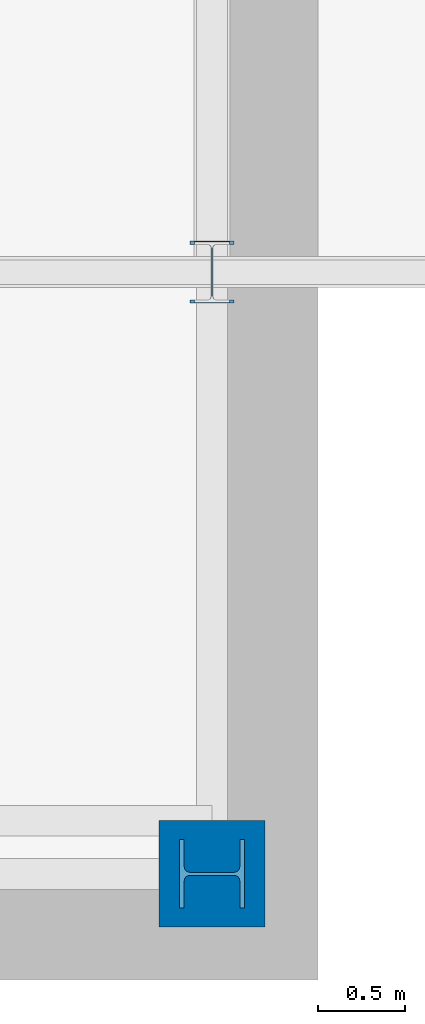
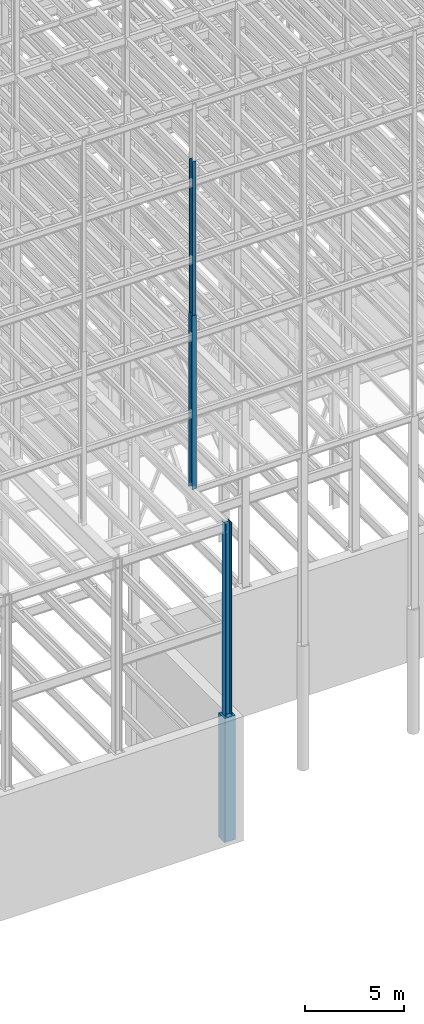
# One storey, part 24 of 150: 4 columns.
"""IFC2X3 building model written with IfcOpenShell, lengths in millimetres."""

from ifc_helpers import new_model, si_unit, frame, origin_with_axes, origin_2d_with_axis, place, context, subcontext, project, spatial, rectangle, i_section, extrude, material, type_object, element, save


model = new_model("IFC2X3")

# Units and contexts
model_context = context("Model", 3, precision=1e-05, world=origin_with_axes())
body_context = subcontext(model_context, "Body", "Model", "MODEL_VIEW")
ifc_project = project(units=[si_unit("LENGTHUNIT", "METRE", prefix="MILLI"), si_unit("AREAUNIT", "SQUARE_METRE"), si_unit("VOLUMEUNIT", "CUBIC_METRE"), si_unit("MASSUNIT", "GRAM", prefix="KILO"), si_unit("TIMEUNIT", "SECOND"), si_unit("PLANEANGLEUNIT", "RADIAN"), si_unit("SOLIDANGLEUNIT", "STERADIAN"), si_unit("THERMODYNAMICTEMPERATUREUNIT", "DEGREE_CELSIUS"), si_unit("LUMINOUSINTENSITYUNIT", "LUMEN")], contexts=[model_context])

# Site, building, storey
site_placement = place(None, origin_with_axes())
site = spatial("IfcSite", under=ifc_project, at=site_placement, CompositionType="ELEMENT")
building_placement = place(site_placement, origin_with_axes())
building = spatial("IfcBuilding", under=site, at=building_placement, Name="Undefined", CompositionType="ELEMENT")
storey_placement = place(building_placement, origin_with_axes())
storey = spatial("IfcBuildingStorey", under=building, at=storey_placement, Name="Undefined", CompositionType="ELEMENT", Elevation=0.0)

# Columns
ifc_material_1 = material(Name="STEEL/A992")
column_type_1 = type_object("IfcColumnType", Name="W14X53", PredefinedType="NOTDEFINED")
column_1_placement = place(storey_placement, frame((43789.6, 3454.40000000001, 46253.4), z_axis=(0.0, 0.0, 1.0), x_axis=(1.0, 0.0, 0.0)))
element("IfcColumn", 1, at=column_1_placement, inside=storey, type_object=column_type_1, material=ifc_material_1, Name="COLUMN", ObjectType="W14X53", context=body_context, shape_type="SweptSolid", body=[
    extrude(i_section(OverallWidth=203.2, OverallDepth=352.425, WebThickness=9.5249, FlangeThickness=16.764, FilletRadius=21.336, at=origin_2d_with_axis()), frame((0.0, 0.0, 9448.8), z_axis=(0.0, 0.0, -1.0), x_axis=(-1.0, 0.0, 0.0)), (0.0, 0.0, 1.0), 9448.8),
])
column_type_2 = type_object("IfcColumnType", Name="W14X68", PredefinedType="NOTDEFINED")
column_2_placement = place(storey_placement, frame((43789.6, 3454.40000000001, 35585.4), z_axis=(0.0, 0.0, 1.0), x_axis=(1.0, 0.0, 0.0)))
element("IfcColumn", 2, at=column_2_placement, inside=storey, type_object=column_type_2, material=ifc_material_1, Name="COLUMN", ObjectType="W14X68", context=body_context, shape_type="SweptSolid", body=[
    extrude(i_section(OverallWidth=254.0, OverallDepth=355.6, WebThickness=11.1125, FlangeThickness=18.288, FilletRadius=21.3994, at=origin_2d_with_axis()), frame((0.0, 0.0, 10667.9989332), z_axis=(0.0, 0.0, -1.0), x_axis=(-1.0, 0.0, 0.0)), (0.0, 0.0, 1.0), 10667.9989332),
])
column_type_3 = type_object("IfcColumnType", Name="W14X145", PredefinedType="NOTDEFINED")
column_3_placement = place(storey_placement, frame((43789.6, 0.0, 22707.6), z_axis=(0.0, 0.0, 1.0), x_axis=(1.0, 0.0, 0.0)))
element("IfcColumn", 3, at=column_3_placement, inside=storey, type_object=column_type_3, material=ifc_material_1, Name="COLUMN", ObjectType="W14X145", context=body_context, shape_type="SweptSolid", body=[
    extrude(i_section(OverallWidth=393.7, OverallDepth=374.65, WebThickness=17.4625, FlangeThickness=27.686, FilletRadius=32.6389, at=origin_2d_with_axis()), frame((0.0, 0.0, 12877.8), z_axis=(0.0, 0.0, -1.0), x_axis=(0.0, -1.0, 0.0)), (0.0, 0.0, 1.0), 12877.8),
])
ifc_material_2 = material(Name="CONCRETE/5000")
column_type_4 = type_object("IfcColumnType", PredefinedType="NOTDEFINED")
column_4_placement = place(storey_placement, frame((43789.6, 0.0, 16154.4), z_axis=(0.0, 0.0, 1.0), x_axis=(1.0, 0.0, 0.0)))
element("IfcColumn", 4, at=column_4_placement, inside=storey, type_object=column_type_4, material=ifc_material_2, Name="COLUMN", context=body_context, shape_type="SweptSolid", body=[
    extrude(rectangle(XDim=609.6, YDim=609.6, at=origin_2d_with_axis()), frame((0.0, 0.0, 7620.0), z_axis=(0.0, 0.0, -1.0), x_axis=(0.0, -1.0, 0.0)), (0.0, 0.0, 1.0), 7620.0),
])

save(model, "model.ifc")
